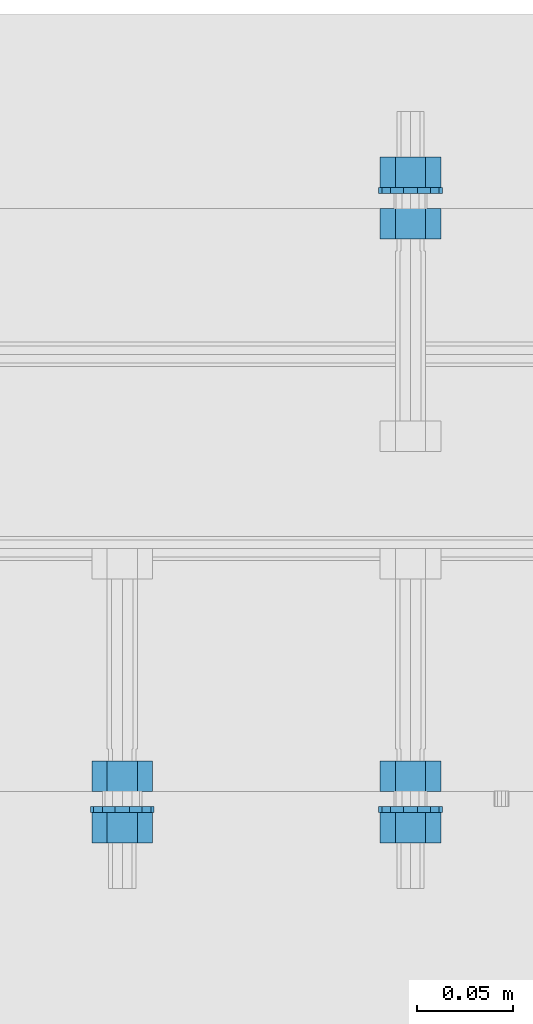
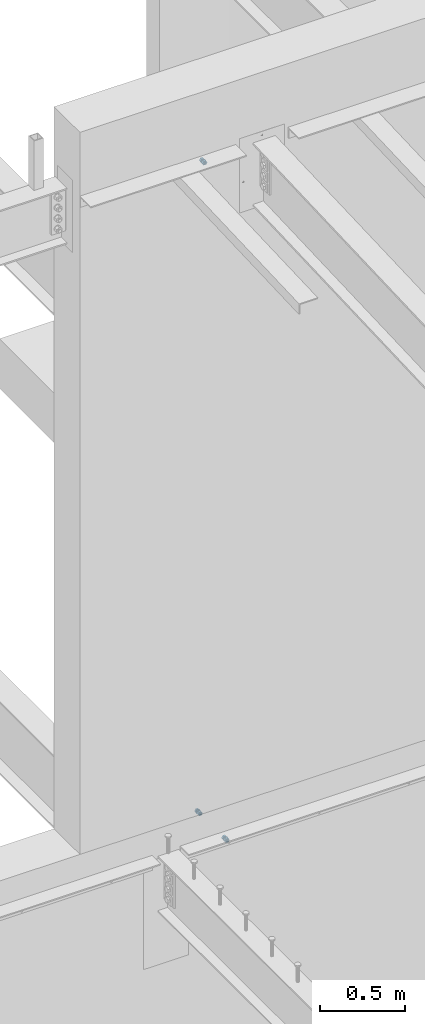
# One storey, part 614 of 975: 9 beams.
"""IFC2X3 building model written with IfcOpenShell, lengths in millimetres."""

from ifc_helpers import new_model, si_unit, frame, origin_with_axes, place, context, subcontext, project, spatial, faceted_brep, material, type_object, element, save


model = new_model("IFC2X3")

# Units and contexts
model_context = context("Model", 3, precision=1e-05, world=origin_with_axes())
body_context = subcontext(model_context, "Body", "Model", "MODEL_VIEW")
ifc_project = project(units=[si_unit("LENGTHUNIT", "METRE", prefix="MILLI"), si_unit("AREAUNIT", "SQUARE_METRE"), si_unit("VOLUMEUNIT", "CUBIC_METRE"), si_unit("MASSUNIT", "GRAM", prefix="KILO"), si_unit("TIMEUNIT", "SECOND"), si_unit("PLANEANGLEUNIT", "RADIAN"), si_unit("SOLIDANGLEUNIT", "STERADIAN"), si_unit("THERMODYNAMICTEMPERATUREUNIT", "DEGREE_CELSIUS"), si_unit("LUMINOUSINTENSITYUNIT", "LUMEN")], contexts=[model_context])

# Site, building, storey
site_placement = place(None, origin_with_axes())
site = spatial("IfcSite", under=ifc_project, at=site_placement, CompositionType="ELEMENT")
building_placement = place(site_placement, origin_with_axes())
building = spatial("IfcBuilding", under=site, at=building_placement, Name="Undefined", CompositionType="ELEMENT")
storey_placement = place(building_placement, origin_with_axes())
storey = spatial("IfcBuildingStorey", under=building, at=storey_placement, Name="Undefined", CompositionType="ELEMENT", Elevation=0.0)

# Beams
ifc_material_1 = material(Name="STEEL/F1554-36")
beam_type_1 = type_object("IfcBeamType", Name="5/8_HEAVY_HEX_NUT", PredefinedType="NOTDEFINED")
beam_1_placement = place(storey_placement, frame((11107.7374941588, 20443.8249991666, 8801.10000023449), z_axis=(0.0, 0.0, 1.0), x_axis=(0.0, 1.0, 0.0)))
element("IfcBeam", 1, at=beam_1_placement, inside=storey, type_object=beam_type_1, material=ifc_material_1, Name="HEADED_ANCHOR_BOLT", ObjectType="5/8_HEAVY_HEX_NUT", context=body_context, shape_type="Brep", body=[
    faceted_brep([(-1.09139364212751e-11, -15.8800001144436, -2.72848410531878e-12), (1.45519152283669e-11, -7.94000005722046, -13.7500000000036), (15.8750000000146, -7.94000005722137, -13.7500000000045), (15.8749999999891, -15.8800001144446, -2.72848410531878e-12), (2.91038304567337e-11, 7.94000005722319, -13.7500000000027), (15.8750000000291, 7.94000005722319, -13.7500000000027), (2.18278728425503e-11, 15.8800001144436, 9.09494701772928e-13), (15.8750000000218, 15.8800001144427, 9.09494701772928e-13), (-7.27595761418343e-12, 7.94000005722046, 13.7500000000027), (15.8749999999927, 7.94000005722046, 13.7500000000027), (-2.18278728425503e-11, -7.94000005722228, 13.7500000000009), (15.8749999999782, -7.94000005722319, 13.7500000000009), (-7.27595761418343e-12, 0.0, 8.72999954223724), (0.0, 3.78780484388062, 7.86545780435881), (15.875, 3.78780484387971, 7.86545780435881), (15.8749999999927, -9.09494701772928e-13, 8.72999954223724), (7.27595761418343e-12, 6.82538848405238, 5.44306568481716), (15.8750000000073, 6.82538848405238, 5.44306568481716), (1.09139364212751e-11, 8.51112022706275, 1.94260765157742), (15.8750000000109, 8.51112022706093, 1.94260765157651), (1.45519152283669e-11, 8.51112022706184, -1.94260765157651), (15.8750000000146, 8.51112022706184, -1.94260765157651), (2.18278728425503e-11, 6.8253884840542, -5.44306568481716), (15.8750000000218, 6.82538848405238, -5.44306568481716), (1.81898940354586e-11, 3.78780484388153, -7.86545780435881), (15.8750000000182, 3.78780484388062, -7.86545780435881), (1.81898940354586e-11, 9.09494701772928e-13, -8.72999954223997), (15.8750000000182, 9.09494701772928e-13, -8.72999954223997), (1.09139364212751e-11, -3.78780484387971, -7.86545780436063), (15.8750000000109, -3.78780484388062, -7.86545780436063), (3.63797880709171e-12, -6.82538848405238, -5.44306568481807), (15.8750000000036, -6.82538848405329, -5.44306568481807), (0.0, -8.51112022706184, -1.94260765157833), (15.875, -8.51112022706184, -1.94260765157833), (-7.27595761418343e-12, -8.51112022706184, 1.9426076515756), (15.8749999999927, -8.51112022706275, 1.9426076515756), (-1.09139364212751e-11, -6.82538848405329, 5.44306568481534), (15.8749999999927, -6.8253884840542, 5.44306568481534), (-7.27595761418343e-12, -3.78780484388062, 7.8654578043579), (15.8749999999927, -3.78780484388153, 7.8654578043579)], [[[0, 1, 2, 3]], [[1, 4, 5, 2]], [[4, 6, 7, 5]], [[6, 8, 9, 7]], [[8, 10, 11, 9]], [[10, 0, 3, 11]], [[12, 13, 14, 15]], [[13, 16, 17, 14]], [[16, 18, 19, 17]], [[18, 20, 21, 19]], [[20, 22, 23, 21]], [[22, 24, 25, 23]], [[24, 26, 27, 25]], [[26, 28, 29, 27]], [[28, 30, 31, 29]], [[30, 32, 33, 31]], [[32, 34, 35, 33]], [[34, 36, 37, 35]], [[36, 38, 39, 37]], [[38, 12, 15, 39]], [[5, 7, 9, 11, 3, 2], [17, 19, 21, 23, 25, 27, 29, 31, 33, 35, 37, 39, 15, 14]], [[10, 8, 6, 4, 1, 0], [38, 36, 34, 32, 30, 28, 26, 24, 22, 20, 18, 16, 13, 12]]]),
])
beam_2_placement = place(storey_placement, frame((11107.7374965746, 20416.8374991663, 8801.10000017628), z_axis=(0.0, 0.0, 1.0), x_axis=(0.0, 1.0, 0.0)))
element("IfcBeam", 2, at=beam_2_placement, inside=storey, type_object=beam_type_1, material=ifc_material_1, Name="HEADED_ANCHOR_BOLT", ObjectType="5/8_HEAVY_HEX_NUT", context=body_context, shape_type="Brep", body=[
    faceted_brep([(-1.09139364212751e-11, -15.8800001144436, -2.72848410531878e-12), (1.45519152283669e-11, -7.94000005722046, -13.7500000000036), (15.8750000000146, -7.94000005722137, -13.7500000000045), (15.8749999999891, -15.8800001144446, -2.72848410531878e-12), (2.91038304567337e-11, 7.94000005722319, -13.7500000000027), (15.8750000000291, 7.94000005722319, -13.7500000000027), (2.18278728425503e-11, 15.8800001144436, 9.09494701772928e-13), (15.8750000000218, 15.8800001144427, 9.09494701772928e-13), (-7.27595761418343e-12, 7.94000005722046, 13.7500000000027), (15.8749999999927, 7.94000005722046, 13.7500000000027), (-2.18278728425503e-11, -7.94000005722228, 13.7500000000009), (15.8749999999782, -7.94000005722319, 13.7500000000009), (-7.27595761418343e-12, 0.0, 8.72999954223724), (0.0, 3.78780484388062, 7.86545780435881), (15.875, 3.78780484387971, 7.86545780435881), (15.8749999999927, -9.09494701772928e-13, 8.72999954223724), (7.27595761418343e-12, 6.82538848405238, 5.44306568481716), (15.8750000000073, 6.82538848405238, 5.44306568481716), (1.09139364212751e-11, 8.51112022706275, 1.94260765157742), (15.8750000000109, 8.51112022706093, 1.94260765157651), (1.45519152283669e-11, 8.51112022706184, -1.94260765157651), (15.8750000000146, 8.51112022706184, -1.94260765157651), (2.18278728425503e-11, 6.8253884840542, -5.44306568481716), (15.8750000000218, 6.82538848405238, -5.44306568481716), (1.81898940354586e-11, 3.78780484388153, -7.86545780435881), (15.8750000000182, 3.78780484388062, -7.86545780435881), (1.81898940354586e-11, 9.09494701772928e-13, -8.72999954223997), (15.8750000000182, 9.09494701772928e-13, -8.72999954223997), (1.09139364212751e-11, -3.78780484387971, -7.86545780436063), (15.8750000000109, -3.78780484388062, -7.86545780436063), (3.63797880709171e-12, -6.82538848405238, -5.44306568481807), (15.8750000000036, -6.82538848405329, -5.44306568481807), (0.0, -8.51112022706184, -1.94260765157833), (15.875, -8.51112022706184, -1.94260765157833), (-7.27595761418343e-12, -8.51112022706184, 1.9426076515756), (15.8749999999927, -8.51112022706275, 1.9426076515756), (-1.09139364212751e-11, -6.82538848405329, 5.44306568481534), (15.8749999999927, -6.8253884840542, 5.44306568481534), (-7.27595761418343e-12, -3.78780484388062, 7.8654578043579), (15.8749999999927, -3.78780484388153, 7.8654578043579)], [[[0, 1, 2, 3]], [[1, 4, 5, 2]], [[4, 6, 7, 5]], [[6, 8, 9, 7]], [[8, 10, 11, 9]], [[10, 0, 3, 11]], [[12, 13, 14, 15]], [[13, 16, 17, 14]], [[16, 18, 19, 17]], [[18, 20, 21, 19]], [[20, 22, 23, 21]], [[22, 24, 25, 23]], [[24, 26, 27, 25]], [[26, 28, 29, 27]], [[28, 30, 31, 29]], [[30, 32, 33, 31]], [[32, 34, 35, 33]], [[34, 36, 37, 35]], [[36, 38, 39, 37]], [[38, 12, 15, 39]], [[5, 7, 9, 11, 3, 2], [17, 19, 21, 23, 25, 27, 29, 31, 33, 35, 37, 39, 15, 14]], [[10, 8, 6, 4, 1, 0], [38, 36, 34, 32, 30, 28, 26, 24, 22, 20, 18, 16, 13, 12]]]),
])
ifc_material_2 = material(Name="STEEL/A36")
beam_3_placement = place(storey_placement, frame((11258.5499755824, 20443.825, 3886.2), z_axis=(0.0, 0.0, -1.0), x_axis=(0.0, 1.0, 0.0)))
element("IfcBeam", 3, at=beam_3_placement, inside=storey, type_object=beam_type_1, material=ifc_material_2, Name="NUT", ObjectType="5/8_HEAVY_HEX_NUT", context=body_context, shape_type="Brep", body=[
    faceted_brep([(-1.09139364212751e-11, -15.8800001144436, -2.72848410531878e-12), (1.45519152283669e-11, -7.94000005722046, -13.7500000000036), (15.8750000000146, -7.94000005722137, -13.7500000000045), (15.8749999999891, -15.8800001144446, -2.72848410531878e-12), (2.91038304567337e-11, 7.94000005722319, -13.7500000000027), (15.8750000000291, 7.94000005722319, -13.7500000000027), (2.18278728425503e-11, 15.8800001144436, 9.09494701772928e-13), (15.8750000000218, 15.8800001144427, 9.09494701772928e-13), (-7.27595761418343e-12, 7.94000005722046, 13.7500000000027), (15.8749999999927, 7.94000005722046, 13.7500000000027), (-2.18278728425503e-11, -7.94000005722228, 13.7500000000009), (15.8749999999782, -7.94000005722319, 13.7500000000009), (-7.27595761418343e-12, 0.0, 8.72999954223724), (0.0, 3.78780484388062, 7.86545780435881), (15.875, 3.78780484387971, 7.86545780435881), (15.8749999999927, -9.09494701772928e-13, 8.72999954223724), (7.27595761418343e-12, 6.82538848405238, 5.44306568481716), (15.8750000000073, 6.82538848405238, 5.44306568481716), (1.09139364212751e-11, 8.51112022706275, 1.94260765157742), (15.8750000000109, 8.51112022706093, 1.94260765157651), (1.45519152283669e-11, 8.51112022706184, -1.94260765157651), (15.8750000000146, 8.51112022706184, -1.94260765157651), (2.18278728425503e-11, 6.8253884840542, -5.44306568481716), (15.8750000000218, 6.82538848405238, -5.44306568481716), (1.81898940354586e-11, 3.78780484388153, -7.86545780435881), (15.8750000000182, 3.78780484388062, -7.86545780435881), (1.81898940354586e-11, 9.09494701772928e-13, -8.72999954223997), (15.8750000000182, 9.09494701772928e-13, -8.72999954223997), (1.09139364212751e-11, -3.78780484387971, -7.86545780436063), (15.8750000000109, -3.78780484388062, -7.86545780436063), (3.63797880709171e-12, -6.82538848405238, -5.44306568481807), (15.8750000000036, -6.82538848405329, -5.44306568481807), (0.0, -8.51112022706184, -1.94260765157833), (15.875, -8.51112022706184, -1.94260765157833), (-7.27595761418343e-12, -8.51112022706184, 1.9426076515756), (15.8749999999927, -8.51112022706275, 1.9426076515756), (-1.09139364212751e-11, -6.82538848405329, 5.44306568481534), (15.8749999999927, -6.8253884840542, 5.44306568481534), (-7.27595761418343e-12, -3.78780484388062, 7.8654578043579), (15.8749999999927, -3.78780484388153, 7.8654578043579)], [[[0, 1, 2, 3]], [[1, 4, 5, 2]], [[4, 6, 7, 5]], [[6, 8, 9, 7]], [[8, 10, 11, 9]], [[10, 0, 3, 11]], [[12, 13, 14, 15]], [[13, 16, 17, 14]], [[16, 18, 19, 17]], [[18, 20, 21, 19]], [[20, 22, 23, 21]], [[22, 24, 25, 23]], [[24, 26, 27, 25]], [[26, 28, 29, 27]], [[28, 30, 31, 29]], [[30, 32, 33, 31]], [[32, 34, 35, 33]], [[34, 36, 37, 35]], [[36, 38, 39, 37]], [[38, 12, 15, 39]], [[5, 7, 9, 11, 3, 2], [17, 19, 21, 23, 25, 27, 29, 31, 33, 35, 37, 39, 15, 14]], [[10, 8, 6, 4, 1, 0], [38, 36, 34, 32, 30, 28, 26, 24, 22, 20, 18, 16, 13, 12]]]),
])
beam_4_placement = place(storey_placement, frame((11258.5499755824, 20748.6249996637, 3886.2), z_axis=(0.0, 0.0, 1.0), x_axis=(0.0, -1.0, 0.0)))
element("IfcBeam", 4, at=beam_4_placement, inside=storey, type_object=beam_type_1, material=ifc_material_2, Name="NUT", ObjectType="5/8_HEAVY_HEX_NUT", context=body_context, shape_type="Brep", body=[
    faceted_brep([(-1.09139364212751e-11, -15.8800001144436, -2.72848410531878e-12), (1.45519152283669e-11, -7.94000005722046, -13.7500000000036), (15.8750000000146, -7.94000005722137, -13.7500000000045), (15.8749999999891, -15.8800001144446, -2.72848410531878e-12), (2.91038304567337e-11, 7.94000005722319, -13.7500000000027), (15.8750000000291, 7.94000005722319, -13.7500000000027), (2.18278728425503e-11, 15.8800001144436, 9.09494701772928e-13), (15.8750000000218, 15.8800001144427, 9.09494701772928e-13), (-7.27595761418343e-12, 7.94000005722046, 13.7500000000027), (15.8749999999927, 7.94000005722046, 13.7500000000027), (-2.18278728425503e-11, -7.94000005722228, 13.7500000000009), (15.8749999999782, -7.94000005722319, 13.7500000000009), (-7.27595761418343e-12, 0.0, 8.72999954223724), (0.0, 3.78780484388062, 7.86545780435881), (15.875, 3.78780484387971, 7.86545780435881), (15.8749999999927, -9.09494701772928e-13, 8.72999954223724), (7.27595761418343e-12, 6.82538848405238, 5.44306568481716), (15.8750000000073, 6.82538848405238, 5.44306568481716), (1.09139364212751e-11, 8.51112022706275, 1.94260765157742), (15.8750000000109, 8.51112022706093, 1.94260765157651), (1.45519152283669e-11, 8.51112022706184, -1.94260765157651), (15.8750000000146, 8.51112022706184, -1.94260765157651), (2.18278728425503e-11, 6.8253884840542, -5.44306568481716), (15.8750000000218, 6.82538848405238, -5.44306568481716), (1.81898940354586e-11, 3.78780484388153, -7.86545780435881), (15.8750000000182, 3.78780484388062, -7.86545780435881), (1.81898940354586e-11, 9.09494701772928e-13, -8.72999954223997), (15.8750000000182, 9.09494701772928e-13, -8.72999954223997), (1.09139364212751e-11, -3.78780484387971, -7.86545780436063), (15.8750000000109, -3.78780484388062, -7.86545780436063), (3.63797880709171e-12, -6.82538848405238, -5.44306568481807), (15.8750000000036, -6.82538848405329, -5.44306568481807), (0.0, -8.51112022706184, -1.94260765157833), (15.875, -8.51112022706184, -1.94260765157833), (-7.27595761418343e-12, -8.51112022706184, 1.9426076515756), (15.8749999999927, -8.51112022706275, 1.9426076515756), (-1.09139364212751e-11, -6.82538848405329, 5.44306568481534), (15.8749999999927, -6.8253884840542, 5.44306568481534), (-7.27595761418343e-12, -3.78780484388062, 7.8654578043579), (15.8749999999927, -3.78780484388153, 7.8654578043579)], [[[0, 1, 2, 3]], [[1, 4, 5, 2]], [[4, 6, 7, 5]], [[6, 8, 9, 7]], [[8, 10, 11, 9]], [[10, 0, 3, 11]], [[12, 13, 14, 15]], [[13, 16, 17, 14]], [[16, 18, 19, 17]], [[18, 20, 21, 19]], [[20, 22, 23, 21]], [[22, 24, 25, 23]], [[24, 26, 27, 25]], [[26, 28, 29, 27]], [[28, 30, 31, 29]], [[30, 32, 33, 31]], [[32, 34, 35, 33]], [[34, 36, 37, 35]], [[36, 38, 39, 37]], [[38, 12, 15, 39]], [[5, 7, 9, 11, 3, 2], [17, 19, 21, 23, 25, 27, 29, 31, 33, 35, 37, 39, 15, 14]], [[10, 8, 6, 4, 1, 0], [38, 36, 34, 32, 30, 28, 26, 24, 22, 20, 18, 16, 13, 12]]]),
])
beam_5_placement = place(storey_placement, frame((11258.5499755824, 20775.6125, 3886.2), z_axis=(0.0, 0.0, 1.0), x_axis=(0.0, -1.0, 0.0)))
element("IfcBeam", 5, at=beam_5_placement, inside=storey, type_object=beam_type_1, material=ifc_material_2, Name="NUT", ObjectType="5/8_HEAVY_HEX_NUT", context=body_context, shape_type="Brep", body=[
    faceted_brep([(-1.09139364212751e-11, -15.8800001144436, -2.72848410531878e-12), (1.45519152283669e-11, -7.94000005722046, -13.7500000000036), (15.8750000000146, -7.94000005722137, -13.7500000000045), (15.8749999999891, -15.8800001144446, -2.72848410531878e-12), (2.91038304567337e-11, 7.94000005722319, -13.7500000000027), (15.8750000000291, 7.94000005722319, -13.7500000000027), (2.18278728425503e-11, 15.8800001144436, 9.09494701772928e-13), (15.8750000000218, 15.8800001144427, 9.09494701772928e-13), (-7.27595761418343e-12, 7.94000005722046, 13.7500000000027), (15.8749999999927, 7.94000005722046, 13.7500000000027), (-2.18278728425503e-11, -7.94000005722228, 13.7500000000009), (15.8749999999782, -7.94000005722319, 13.7500000000009), (-7.27595761418343e-12, 0.0, 8.72999954223724), (0.0, 3.78780484388062, 7.86545780435881), (15.875, 3.78780484387971, 7.86545780435881), (15.8749999999927, -9.09494701772928e-13, 8.72999954223724), (7.27595761418343e-12, 6.82538848405238, 5.44306568481716), (15.8750000000073, 6.82538848405238, 5.44306568481716), (1.09139364212751e-11, 8.51112022706275, 1.94260765157742), (15.8750000000109, 8.51112022706093, 1.94260765157651), (1.45519152283669e-11, 8.51112022706184, -1.94260765157651), (15.8750000000146, 8.51112022706184, -1.94260765157651), (2.18278728425503e-11, 6.8253884840542, -5.44306568481716), (15.8750000000218, 6.82538848405238, -5.44306568481716), (1.81898940354586e-11, 3.78780484388153, -7.86545780435881), (15.8750000000182, 3.78780484388062, -7.86545780435881), (1.81898940354586e-11, 9.09494701772928e-13, -8.72999954223997), (15.8750000000182, 9.09494701772928e-13, -8.72999954223997), (1.09139364212751e-11, -3.78780484387971, -7.86545780436063), (15.8750000000109, -3.78780484388062, -7.86545780436063), (3.63797880709171e-12, -6.82538848405238, -5.44306568481807), (15.8750000000036, -6.82538848405329, -5.44306568481807), (0.0, -8.51112022706184, -1.94260765157833), (15.875, -8.51112022706184, -1.94260765157833), (-7.27595761418343e-12, -8.51112022706184, 1.9426076515756), (15.8749999999927, -8.51112022706275, 1.9426076515756), (-1.09139364212751e-11, -6.82538848405329, 5.44306568481534), (15.8749999999927, -6.8253884840542, 5.44306568481534), (-7.27595761418343e-12, -3.78780484388062, 7.8654578043579), (15.8749999999927, -3.78780484388153, 7.8654578043579)], [[[0, 1, 2, 3]], [[1, 4, 5, 2]], [[4, 6, 7, 5]], [[6, 8, 9, 7]], [[8, 10, 11, 9]], [[10, 0, 3, 11]], [[12, 13, 14, 15]], [[13, 16, 17, 14]], [[16, 18, 19, 17]], [[18, 20, 21, 19]], [[20, 22, 23, 21]], [[22, 24, 25, 23]], [[24, 26, 27, 25]], [[26, 28, 29, 27]], [[28, 30, 31, 29]], [[30, 32, 33, 31]], [[32, 34, 35, 33]], [[34, 36, 37, 35]], [[36, 38, 39, 37]], [[38, 12, 15, 39]], [[5, 7, 9, 11, 3, 2], [17, 19, 21, 23, 25, 27, 29, 31, 33, 35, 37, 39, 15, 14]], [[10, 8, 6, 4, 1, 0], [38, 36, 34, 32, 30, 28, 26, 24, 22, 20, 18, 16, 13, 12]]]),
])
beam_6_placement = place(storey_placement, frame((11258.5499755824, 20416.8375, 3886.2), z_axis=(0.0, 0.0, -1.0), x_axis=(0.0, 1.0, 0.0)))
element("IfcBeam", 6, at=beam_6_placement, inside=storey, type_object=beam_type_1, material=ifc_material_2, Name="NUT", ObjectType="5/8_HEAVY_HEX_NUT", context=body_context, shape_type="Brep", body=[
    faceted_brep([(-1.09139364212751e-11, -15.8800001144436, -2.72848410531878e-12), (1.45519152283669e-11, -7.94000005722046, -13.7500000000036), (15.8750000000146, -7.94000005722137, -13.7500000000045), (15.8749999999891, -15.8800001144446, -2.72848410531878e-12), (2.91038304567337e-11, 7.94000005722319, -13.7500000000027), (15.8750000000291, 7.94000005722319, -13.7500000000027), (2.18278728425503e-11, 15.8800001144436, 9.09494701772928e-13), (15.8750000000218, 15.8800001144427, 9.09494701772928e-13), (-7.27595761418343e-12, 7.94000005722046, 13.7500000000027), (15.8749999999927, 7.94000005722046, 13.7500000000027), (-2.18278728425503e-11, -7.94000005722228, 13.7500000000009), (15.8749999999782, -7.94000005722319, 13.7500000000009), (-7.27595761418343e-12, 0.0, 8.72999954223724), (0.0, 3.78780484388062, 7.86545780435881), (15.875, 3.78780484387971, 7.86545780435881), (15.8749999999927, -9.09494701772928e-13, 8.72999954223724), (7.27595761418343e-12, 6.82538848405238, 5.44306568481716), (15.8750000000073, 6.82538848405238, 5.44306568481716), (1.09139364212751e-11, 8.51112022706275, 1.94260765157742), (15.8750000000109, 8.51112022706093, 1.94260765157651), (1.45519152283669e-11, 8.51112022706184, -1.94260765157651), (15.8750000000146, 8.51112022706184, -1.94260765157651), (2.18278728425503e-11, 6.8253884840542, -5.44306568481716), (15.8750000000218, 6.82538848405238, -5.44306568481716), (1.81898940354586e-11, 3.78780484388153, -7.86545780435881), (15.8750000000182, 3.78780484388062, -7.86545780435881), (1.81898940354586e-11, 9.09494701772928e-13, -8.72999954223997), (15.8750000000182, 9.09494701772928e-13, -8.72999954223997), (1.09139364212751e-11, -3.78780484387971, -7.86545780436063), (15.8750000000109, -3.78780484388062, -7.86545780436063), (3.63797880709171e-12, -6.82538848405238, -5.44306568481807), (15.8750000000036, -6.82538848405329, -5.44306568481807), (0.0, -8.51112022706184, -1.94260765157833), (15.875, -8.51112022706184, -1.94260765157833), (-7.27595761418343e-12, -8.51112022706184, 1.9426076515756), (15.8749999999927, -8.51112022706275, 1.9426076515756), (-1.09139364212751e-11, -6.82538848405329, 5.44306568481534), (15.8749999999927, -6.8253884840542, 5.44306568481534), (-7.27595761418343e-12, -3.78780484388062, 7.8654578043579), (15.8749999999927, -3.78780484388153, 7.8654578043579)], [[[0, 1, 2, 3]], [[1, 4, 5, 2]], [[4, 6, 7, 5]], [[6, 8, 9, 7]], [[8, 10, 11, 9]], [[10, 0, 3, 11]], [[12, 13, 14, 15]], [[13, 16, 17, 14]], [[16, 18, 19, 17]], [[18, 20, 21, 19]], [[20, 22, 23, 21]], [[22, 24, 25, 23]], [[24, 26, 27, 25]], [[26, 28, 29, 27]], [[28, 30, 31, 29]], [[30, 32, 33, 31]], [[32, 34, 35, 33]], [[34, 36, 37, 35]], [[36, 38, 39, 37]], [[38, 12, 15, 39]], [[5, 7, 9, 11, 3, 2], [17, 19, 21, 23, 25, 27, 29, 31, 33, 35, 37, 39, 15, 14]], [[10, 8, 6, 4, 1, 0], [38, 36, 34, 32, 30, 28, 26, 24, 22, 20, 18, 16, 13, 12]]]),
])
beam_type_2 = type_object("IfcBeamType", Name="5/8_WASHER", PredefinedType="NOTDEFINED")
beam_7_placement = place(storey_placement, frame((11107.7374951006, 20432.7124991661, 8801.10000026254), z_axis=(0.0, 0.0, 1.0), x_axis=(0.0, 1.0, 0.0)))
element("IfcBeam", 7, at=beam_7_placement, inside=storey, type_object=beam_type_2, material=ifc_material_1, Name="HEADED_ANCHOR_BOLT", ObjectType="5/8_WASHER", context=body_context, shape_type="Brep", body=[
    faceted_brep([(1.09139364212751e-11, -16.670000076293, -2.72848410531878e-12), (2.18278728425503e-11, -15.0191510966704, -7.23284196419536), (3.1750000000211, -15.0191510966711, -7.23284196419627), (3.17500000001019, -16.6700000762937, -1.81898940354586e-12), (2.91038304567337e-11, -10.3935750445523, -13.0331308723944), (3.17500000002838, -10.3935750445526, -13.0331308723953), (2.91038304567337e-11, -3.70942398602756, -16.2520483704566), (3.17500000002838, -3.70942398602779, -16.2520483704566), (2.5465851649642e-11, 3.70942398602961, -16.2520483704557), (3.17500000002474, 3.70942398602961, -16.2520483704566), (1.45519152283669e-11, 10.3935750445542, -13.0331308723935), (3.17500000001382, 10.3935750445537, -13.0331308723944), (0.0, 15.0191510966717, -7.23284196419354), (3.17499999999927, 15.0191510966713, -7.23284196419354), (-7.27595761418343e-12, 16.6700000762933, 0.0), (3.174999999992, 16.6700000762928, -9.09494701772928e-13), (-1.81898940354586e-11, 15.0191510966706, 7.23284196419354), (3.17499999998108, 15.0191510966704, 7.23284196419354), (-2.5465851649642e-11, 10.3935750445519, 13.0331308723926), (3.17499999997381, 10.3935750445517, 13.0331308723926), (-2.5465851649642e-11, 3.70942398602733, 16.2520483704538), (3.17499999997381, 3.7094239860271, 16.2520483704529), (-2.18278728425503e-11, -3.70942398602983, 16.2520483704529), (3.17499999997744, -3.70942398603006, 16.2520483704538), (-1.09139364212751e-11, -10.3935750445542, 13.0331308723908), (3.17499999998836, -10.3935750445544, 13.0331308723908), (0.0, -15.0191510966717, 7.23284196419172), (3.17499999999927, -15.019151096672, 7.23284196419081), (-7.27595761418343e-12, 0.0, 8.72999954223724), (0.0, 3.78780484388062, 7.86545780435881), (3.17499999998472, 3.78780484387903, 7.86545780435699), (3.17499999998836, -9.09494701772928e-13, 8.72999954223542), (7.27595761418343e-12, 6.82538848405238, 5.44306568481716), (3.17499999998836, 6.82538848405102, 5.44306568481534), (1.09139364212751e-11, 8.51112022706275, 1.94260765157742), (3.174999999992, 8.51112022705979, 1.94260765157651), (1.45519152283669e-11, 8.51112022706184, -1.94260765157651), (3.17499999999563, 8.51112022706025, -1.94260765157742), (2.18278728425503e-11, 6.8253884840542, -5.44306568481716), (3.17500000000655, 6.8253884840517, -5.44306568481807), (1.81898940354586e-11, 3.78780484388153, -7.86545780435881), (3.17500000001019, 3.78780484388017, -7.86545780435972), (1.81898940354586e-11, 9.09494701772928e-13, -8.72999954223997), (3.17500000001382, 6.82121026329696e-13, -8.72999954223997), (1.09139364212751e-11, -3.78780484387971, -7.86545780436063), (3.17500000001382, -3.78780484387994, -7.86545780436063), (3.63797880709171e-12, -6.82538848405238, -5.44306568481807), (3.17500000001019, -6.82538848405147, -5.44306568481898), (0.0, -8.51112022706184, -1.94260765157833), (3.17500000001019, -8.5111202270607, -1.94260765157924), (-7.27595761418343e-12, -8.51112022706184, 1.9426076515756), (3.17500000000291, -8.51112022706093, 1.94260765157469), (-1.09139364212751e-11, -6.82538848405329, 5.44306568481534), (3.17499999999563, -6.82538848405238, 5.44306568481534), (-7.27595761418343e-12, -3.78780484388062, 7.8654578043579), (3.174999999992, -3.78780484388085, 7.86545780435699)], [[[0, 1, 2, 3]], [[1, 4, 5, 2]], [[4, 6, 7, 5]], [[6, 8, 9, 7]], [[8, 10, 11, 9]], [[10, 12, 13, 11]], [[12, 14, 15, 13]], [[14, 16, 17, 15]], [[16, 18, 19, 17]], [[18, 20, 21, 19]], [[20, 22, 23, 21]], [[22, 24, 25, 23]], [[24, 26, 27, 25]], [[26, 0, 3, 27]], [[28, 29, 30, 31]], [[29, 32, 33, 30]], [[32, 34, 35, 33]], [[34, 36, 37, 35]], [[36, 38, 39, 37]], [[38, 40, 41, 39]], [[40, 42, 43, 41]], [[42, 44, 45, 43]], [[44, 46, 47, 45]], [[46, 48, 49, 47]], [[48, 50, 51, 49]], [[50, 52, 53, 51]], [[52, 54, 55, 53]], [[54, 28, 31, 55]], [[5, 7, 9, 11, 13, 15, 17, 19, 21, 23, 25, 27, 3, 2], [33, 35, 37, 39, 41, 43, 45, 47, 49, 51, 53, 55, 31, 30]], [[26, 24, 22, 20, 18, 16, 14, 12, 10, 8, 6, 4, 1, 0], [54, 52, 50, 48, 46, 44, 42, 40, 38, 36, 34, 32, 29, 28]]]),
])
beam_8_placement = place(storey_placement, frame((11258.5499755824, 20759.7375, 3886.2), z_axis=(0.0, 0.0, 1.0), x_axis=(0.0, -1.0, 0.0)))
element("IfcBeam", 8, at=beam_8_placement, inside=storey, type_object=beam_type_2, material=ifc_material_2, Name="WASHER", ObjectType="5/8_WASHER", context=body_context, shape_type="Brep", body=[
    faceted_brep([(1.09139364212751e-11, -16.670000076293, -2.72848410531878e-12), (2.18278728425503e-11, -15.0191510966704, -7.23284196419536), (3.1750000000211, -15.0191510966711, -7.23284196419627), (3.17500000001019, -16.6700000762937, -1.81898940354586e-12), (2.91038304567337e-11, -10.3935750445523, -13.0331308723944), (3.17500000002838, -10.3935750445526, -13.0331308723953), (2.91038304567337e-11, -3.70942398602756, -16.2520483704566), (3.17500000002838, -3.70942398602779, -16.2520483704566), (2.5465851649642e-11, 3.70942398602961, -16.2520483704557), (3.17500000002474, 3.70942398602961, -16.2520483704566), (1.45519152283669e-11, 10.3935750445542, -13.0331308723935), (3.17500000001382, 10.3935750445537, -13.0331308723944), (0.0, 15.0191510966717, -7.23284196419354), (3.17499999999927, 15.0191510966713, -7.23284196419354), (-7.27595761418343e-12, 16.6700000762933, 0.0), (3.174999999992, 16.6700000762928, -9.09494701772928e-13), (-1.81898940354586e-11, 15.0191510966706, 7.23284196419354), (3.17499999998108, 15.0191510966704, 7.23284196419354), (-2.5465851649642e-11, 10.3935750445519, 13.0331308723926), (3.17499999997381, 10.3935750445517, 13.0331308723926), (-2.5465851649642e-11, 3.70942398602733, 16.2520483704538), (3.17499999997381, 3.7094239860271, 16.2520483704529), (-2.18278728425503e-11, -3.70942398602983, 16.2520483704529), (3.17499999997744, -3.70942398603006, 16.2520483704538), (-1.09139364212751e-11, -10.3935750445542, 13.0331308723908), (3.17499999998836, -10.3935750445544, 13.0331308723908), (0.0, -15.0191510966717, 7.23284196419172), (3.17499999999927, -15.019151096672, 7.23284196419081), (-7.27595761418343e-12, 0.0, 8.72999954223724), (0.0, 3.78780484388062, 7.86545780435881), (3.17499999998472, 3.78780484387903, 7.86545780435699), (3.17499999998836, -9.09494701772928e-13, 8.72999954223542), (7.27595761418343e-12, 6.82538848405238, 5.44306568481716), (3.17499999998836, 6.82538848405102, 5.44306568481534), (1.09139364212751e-11, 8.51112022706275, 1.94260765157742), (3.174999999992, 8.51112022705979, 1.94260765157651), (1.45519152283669e-11, 8.51112022706184, -1.94260765157651), (3.17499999999563, 8.51112022706025, -1.94260765157742), (2.18278728425503e-11, 6.8253884840542, -5.44306568481716), (3.17500000000655, 6.8253884840517, -5.44306568481807), (1.81898940354586e-11, 3.78780484388153, -7.86545780435881), (3.17500000001019, 3.78780484388017, -7.86545780435972), (1.81898940354586e-11, 9.09494701772928e-13, -8.72999954223997), (3.17500000001382, 6.82121026329696e-13, -8.72999954223997), (1.09139364212751e-11, -3.78780484387971, -7.86545780436063), (3.17500000001382, -3.78780484387994, -7.86545780436063), (3.63797880709171e-12, -6.82538848405238, -5.44306568481807), (3.17500000001019, -6.82538848405147, -5.44306568481898), (0.0, -8.51112022706184, -1.94260765157833), (3.17500000001019, -8.5111202270607, -1.94260765157924), (-7.27595761418343e-12, -8.51112022706184, 1.9426076515756), (3.17500000000291, -8.51112022706093, 1.94260765157469), (-1.09139364212751e-11, -6.82538848405329, 5.44306568481534), (3.17499999999563, -6.82538848405238, 5.44306568481534), (-7.27595761418343e-12, -3.78780484388062, 7.8654578043579), (3.174999999992, -3.78780484388085, 7.86545780435699)], [[[0, 1, 2, 3]], [[1, 4, 5, 2]], [[4, 6, 7, 5]], [[6, 8, 9, 7]], [[8, 10, 11, 9]], [[10, 12, 13, 11]], [[12, 14, 15, 13]], [[14, 16, 17, 15]], [[16, 18, 19, 17]], [[18, 20, 21, 19]], [[20, 22, 23, 21]], [[22, 24, 25, 23]], [[24, 26, 27, 25]], [[26, 0, 3, 27]], [[28, 29, 30, 31]], [[29, 32, 33, 30]], [[32, 34, 35, 33]], [[34, 36, 37, 35]], [[36, 38, 39, 37]], [[38, 40, 41, 39]], [[40, 42, 43, 41]], [[42, 44, 45, 43]], [[44, 46, 47, 45]], [[46, 48, 49, 47]], [[48, 50, 51, 49]], [[50, 52, 53, 51]], [[52, 54, 55, 53]], [[54, 28, 31, 55]], [[5, 7, 9, 11, 13, 15, 17, 19, 21, 23, 25, 27, 3, 2], [33, 35, 37, 39, 41, 43, 45, 47, 49, 51, 53, 55, 31, 30]], [[26, 24, 22, 20, 18, 16, 14, 12, 10, 8, 6, 4, 1, 0], [54, 52, 50, 48, 46, 44, 42, 40, 38, 36, 34, 32, 29, 28]]]),
])
beam_9_placement = place(storey_placement, frame((11258.5499755824, 20432.7125, 3886.2), z_axis=(0.0, 0.0, -1.0), x_axis=(0.0, 1.0, 0.0)))
element("IfcBeam", 9, at=beam_9_placement, inside=storey, type_object=beam_type_2, material=ifc_material_2, Name="WASHER", ObjectType="5/8_WASHER", context=body_context, shape_type="Brep", body=[
    faceted_brep([(1.09139364212751e-11, -16.670000076293, -2.72848410531878e-12), (2.18278728425503e-11, -15.0191510966704, -7.23284196419536), (3.1750000000211, -15.0191510966711, -7.23284196419627), (3.17500000001019, -16.6700000762937, -1.81898940354586e-12), (2.91038304567337e-11, -10.3935750445523, -13.0331308723944), (3.17500000002838, -10.3935750445526, -13.0331308723953), (2.91038304567337e-11, -3.70942398602756, -16.2520483704566), (3.17500000002838, -3.70942398602779, -16.2520483704566), (2.5465851649642e-11, 3.70942398602961, -16.2520483704557), (3.17500000002474, 3.70942398602961, -16.2520483704566), (1.45519152283669e-11, 10.3935750445542, -13.0331308723935), (3.17500000001382, 10.3935750445537, -13.0331308723944), (0.0, 15.0191510966717, -7.23284196419354), (3.17499999999927, 15.0191510966713, -7.23284196419354), (-7.27595761418343e-12, 16.6700000762933, 0.0), (3.174999999992, 16.6700000762928, -9.09494701772928e-13), (-1.81898940354586e-11, 15.0191510966706, 7.23284196419354), (3.17499999998108, 15.0191510966704, 7.23284196419354), (-2.5465851649642e-11, 10.3935750445519, 13.0331308723926), (3.17499999997381, 10.3935750445517, 13.0331308723926), (-2.5465851649642e-11, 3.70942398602733, 16.2520483704538), (3.17499999997381, 3.7094239860271, 16.2520483704529), (-2.18278728425503e-11, -3.70942398602983, 16.2520483704529), (3.17499999997744, -3.70942398603006, 16.2520483704538), (-1.09139364212751e-11, -10.3935750445542, 13.0331308723908), (3.17499999998836, -10.3935750445544, 13.0331308723908), (0.0, -15.0191510966717, 7.23284196419172), (3.17499999999927, -15.019151096672, 7.23284196419081), (-7.27595761418343e-12, 0.0, 8.72999954223724), (0.0, 3.78780484388062, 7.86545780435881), (3.17499999998472, 3.78780484387903, 7.86545780435699), (3.17499999998836, -9.09494701772928e-13, 8.72999954223542), (7.27595761418343e-12, 6.82538848405238, 5.44306568481716), (3.17499999998836, 6.82538848405102, 5.44306568481534), (1.09139364212751e-11, 8.51112022706275, 1.94260765157742), (3.174999999992, 8.51112022705979, 1.94260765157651), (1.45519152283669e-11, 8.51112022706184, -1.94260765157651), (3.17499999999563, 8.51112022706025, -1.94260765157742), (2.18278728425503e-11, 6.8253884840542, -5.44306568481716), (3.17500000000655, 6.8253884840517, -5.44306568481807), (1.81898940354586e-11, 3.78780484388153, -7.86545780435881), (3.17500000001019, 3.78780484388017, -7.86545780435972), (1.81898940354586e-11, 9.09494701772928e-13, -8.72999954223997), (3.17500000001382, 6.82121026329696e-13, -8.72999954223997), (1.09139364212751e-11, -3.78780484387971, -7.86545780436063), (3.17500000001382, -3.78780484387994, -7.86545780436063), (3.63797880709171e-12, -6.82538848405238, -5.44306568481807), (3.17500000001019, -6.82538848405147, -5.44306568481898), (0.0, -8.51112022706184, -1.94260765157833), (3.17500000001019, -8.5111202270607, -1.94260765157924), (-7.27595761418343e-12, -8.51112022706184, 1.9426076515756), (3.17500000000291, -8.51112022706093, 1.94260765157469), (-1.09139364212751e-11, -6.82538848405329, 5.44306568481534), (3.17499999999563, -6.82538848405238, 5.44306568481534), (-7.27595761418343e-12, -3.78780484388062, 7.8654578043579), (3.174999999992, -3.78780484388085, 7.86545780435699)], [[[0, 1, 2, 3]], [[1, 4, 5, 2]], [[4, 6, 7, 5]], [[6, 8, 9, 7]], [[8, 10, 11, 9]], [[10, 12, 13, 11]], [[12, 14, 15, 13]], [[14, 16, 17, 15]], [[16, 18, 19, 17]], [[18, 20, 21, 19]], [[20, 22, 23, 21]], [[22, 24, 25, 23]], [[24, 26, 27, 25]], [[26, 0, 3, 27]], [[28, 29, 30, 31]], [[29, 32, 33, 30]], [[32, 34, 35, 33]], [[34, 36, 37, 35]], [[36, 38, 39, 37]], [[38, 40, 41, 39]], [[40, 42, 43, 41]], [[42, 44, 45, 43]], [[44, 46, 47, 45]], [[46, 48, 49, 47]], [[48, 50, 51, 49]], [[50, 52, 53, 51]], [[52, 54, 55, 53]], [[54, 28, 31, 55]], [[5, 7, 9, 11, 13, 15, 17, 19, 21, 23, 25, 27, 3, 2], [33, 35, 37, 39, 41, 43, 45, 47, 49, 51, 53, 55, 31, 30]], [[26, 24, 22, 20, 18, 16, 14, 12, 10, 8, 6, 4, 1, 0], [54, 52, 50, 48, 46, 44, 42, 40, 38, 36, 34, 32, 29, 28]]]),
])

save(model, "model.ifc")
